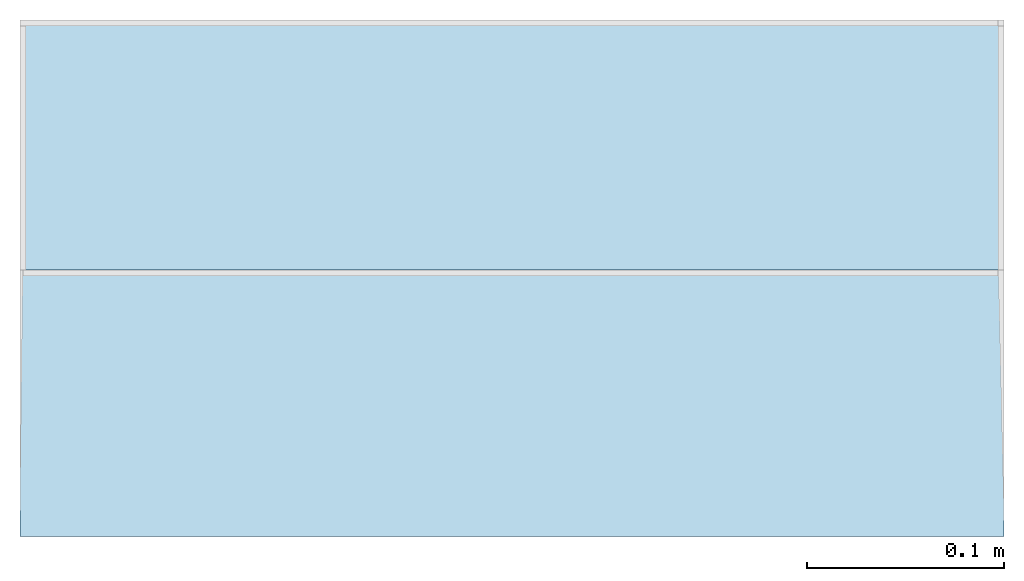
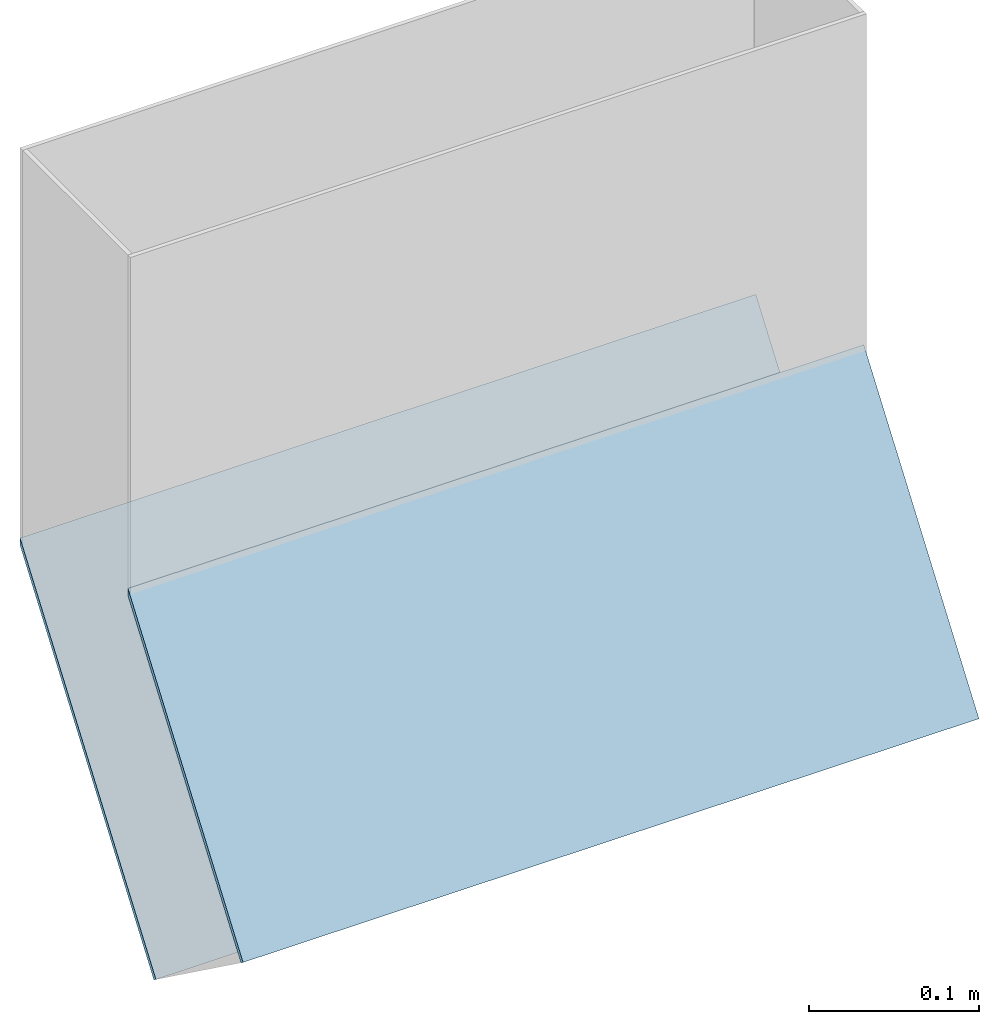
# One storey, part 1 of 2: 2 roofs.
"""IFC2X3 building model written with IfcOpenShell, lengths in metres."""

import ifcopenshell
import ifcopenshell.guid

model = None  # the IFC model being written
_history = None  # IfcOwnerHistory: only IFC2X3 demands one
_inside = {}  # id of a spatial element -> (the spatial element, [elements in it])
_under = {}  # id of a project, library or spatial element -> (it, [spatial elements below it])
_declared = {}  # id of a project -> (the project, [libraries it declares])
_typed = {}  # id of a type object -> (the type object, [elements of that type])
_made_of = {}  # id of a material, layer set ... -> (it, [elements and type objects made of it])


def new_model(schema):
    """Start an empty IFC model of exactly this schema.

    Asked for "IFC4X3", IfcOpenShell would pick the latest addendum, in which some entities
    have other attributes; the version numbers below select the first issue.
    IFC2X3 requires an IfcOwnerHistory on every rooted entity: one is made here for all.
    """
    global model, _history
    if schema == "IFC4X3":
        model = ifcopenshell.file(schema_version=(4, 3, 0, 0))
    else:
        model = ifcopenshell.file(schema=schema)
    _inside.clear()
    _under.clear()
    _declared.clear()
    _typed.clear()
    _made_of.clear()
    _history = None
    if model.schema == "IFC2X3":
        org = make("IfcOrganization", Name="unknown")
        user = make(
            "IfcPersonAndOrganization",
            ThePerson=make("IfcPerson", FamilyName="unknown"),
            TheOrganization=org,
        )
        app = make(
            "IfcApplication",
            ApplicationDeveloper=org,
            Version="unknown",
            ApplicationFullName="unknown",
            ApplicationIdentifier="unknown",
        )
        _history = make(
            "IfcOwnerHistory",
            OwningUser=user,
            OwningApplication=app,
            ChangeAction="ADDED",
            CreationDate=0,
        )
    return model


def make(cls, **values):
    """One entity of the class cls with the attributes given. An attribute that is None is left unset."""
    return model.create_entity(
        cls, **{name: value for name, value in values.items() if value is not None}
    )


def entity(cls, *values):
    """Any entity or typed value of the class cls, its attributes in the order of the schema. None: left unset."""
    e = model.create_entity(cls)
    for i, value in enumerate(values):
        if value is not None:
            e[i] = value
    return e


def rooted(cls, **values):
    """An entity with a GlobalId (a new one), such as an element, a storey or a relation."""
    return make(cls, GlobalId=ifcopenshell.guid.new(), OwnerHistory=_history, **values)


def si_unit(unit_type, name, prefix=None):
    """IfcSIUnit, for example si_unit("LENGTHUNIT", "METRE", prefix="MILLI")."""
    return make("IfcSIUnit", UnitType=unit_type, Prefix=prefix, Name=name)


def converted_unit(unit_type, name, factor, base, dimensions=None, offset=None):
    """IfcConversionBasedUnit, such as the inch: factor (a typed value) times the base unit."""
    return make(
        "IfcConversionBasedUnit"
        if offset is None
        else "IfcConversionBasedUnitWithOffset",
        ConversionOffset=offset,
        Dimensions=None
        if dimensions is None
        else entity("IfcDimensionalExponents", *dimensions),
        UnitType=unit_type,
        Name=name,
        ConversionFactor=make(
            "IfcMeasureWithUnit", ValueComponent=factor, UnitComponent=base
        ),
    )


def derived_unit(unit_type, elements):
    """IfcDerivedUnit: a product of units, each with its exponent."""
    return make(
        "IfcDerivedUnit",
        Elements=[
            make("IfcDerivedUnitElement", Unit=unit, Exponent=power)
            for unit, power in elements
        ],
        UnitType=unit_type,
    )


def money_unit(currency):
    """IfcMonetaryUnit."""
    return make("IfcMonetaryUnit", Currency=currency)


def assignment(units):
    """IfcUnitAssignment: the units of a project."""
    return None if units is None else make("IfcUnitAssignment", Units=units)


def point(xyz):
    """IfcCartesianPoint."""
    return None if xyz is None else make("IfcCartesianPoint", Coordinates=xyz)


def direction(xyz):
    """IfcDirection."""
    return None if xyz is None else make("IfcDirection", DirectionRatios=xyz)


def frame(location, z_axis=None, x_axis=None):
    """IfcAxis2Placement3D, a coordinate frame: its origin and axes. An axis left out is left unset."""
    return make(
        "IfcAxis2Placement3D",
        Location=point(location),
        Axis=direction(z_axis),
        RefDirection=direction(x_axis),
    )


def origin_with_axes():
    """The frame at (0, 0, 0) with the z axis (0, 0, 1) and the x axis (1, 0, 0) written out."""
    return frame((0.0, 0.0, 0.0), z_axis=(0.0, 0.0, 1.0), x_axis=(1.0, 0.0, 0.0))


def place(relative_to, where):
    """IfcLocalPlacement: puts the frame where relative to a parent placement (None: the world)."""
    return make(
        "IfcLocalPlacement", PlacementRelTo=relative_to, RelativePlacement=where
    )


def context(
    kind, dimensions, precision=None, world=None, true_north=None, identifier=None
):
    """IfcGeometricRepresentationContext, for example the 3D "Model" context."""
    return make(
        "IfcGeometricRepresentationContext",
        ContextIdentifier=identifier,
        ContextType=kind,
        CoordinateSpaceDimension=dimensions,
        Precision=precision,
        WorldCoordinateSystem=world,
        TrueNorth=true_north,
    )


def subcontext(parent, identifier, kind, view, scale=None):
    """IfcGeometricRepresentationSubContext, for example "Body" below "Model"."""
    return make(
        "IfcGeometricRepresentationSubContext",
        ContextIdentifier=identifier,
        ContextType=kind,
        ParentContext=parent,
        TargetScale=scale,
        TargetView=view,
    )


def project(units=None, contexts=None):
    """IfcProject with its units and contexts."""
    return rooted(
        "IfcProject",
        Name="project",
        RepresentationContexts=contexts,
        UnitsInContext=assignment(units),
    )


def spatial(cls, under=None, at=None, **own):
    """A site, building, storey or space (cls), placed at a placement, below another one or the project."""
    s = rooted(cls, ObjectPlacement=at, **own)
    if under is not None:
        _under.setdefault(under.id(), (under, []))[1].append(s)
    return s


def faces_of(points, faces, orient=None, outer=None):
    """IfcFace entities. A face is a list of loops; a loop is a list of indices into points, from 0.

    orient and outer hold one flag for each loop. By default every Orientation is true, the
    first loop of a face is its IfcFaceOuterBound and the others are IfcFaceBound.
    """
    made = []
    for i, loops in enumerate(faces):
        bounds = []
        for j, loop in enumerate(loops):
            is_outer = j == 0 if outer is None else outer[i][j]
            bounds.append(
                make(
                    "IfcFaceOuterBound" if is_outer else "IfcFaceBound",
                    Bound=make("IfcPolyLoop", Polygon=[points[k] for k in loop]),
                    Orientation=True if orient is None else orient[i][j],
                )
            )
        made.append(make("IfcFace", Bounds=bounds))
    return made


def faceted_brep(points, faces, orient=None, outer=None, voids=None):
    """IfcFacetedBrep: a solid bounded by flat faces; with voids (closed shells), ...WithVoids."""
    shared = [point(p) for p in points]
    hull = make("IfcClosedShell", CfsFaces=faces_of(shared, faces, orient, outer))
    if voids is None:
        return make("IfcFacetedBrep", Outer=hull)
    return make(
        "IfcFacetedBrepWithVoids",
        Outer=hull,
        Voids=[
            make(cls, CfsFaces=faces_of(shared, fs, o, b)) for cls, fs, o, b in voids
        ],
    )


def shape(context_of_items, identifier, shape_type, items):
    """IfcShapeRepresentation: the items that make up one representation, for example the "Body"."""
    return make(
        "IfcShapeRepresentation",
        ContextOfItems=context_of_items,
        RepresentationIdentifier=identifier,
        RepresentationType=shape_type,
        Items=items,
    )


def material(Name=None, Category=None):
    """IfcMaterial."""
    return make("IfcMaterial", Name=Name, Category=Category)


def made_of(thing, what):
    """Note that an element or type object is made of a material, layer set ...; save() writes the relation."""
    if what is not None:
        _made_of.setdefault(what.id(), (what, []))[1].append(thing)
    return thing


def element(
    cls,
    number,
    at=None,
    inside=None,
    cuts=None,
    type_object=None,
    material=None,
    context=None,
    identifier="Body",
    shape_type=None,
    held_by="IfcProductDefinitionShape",
    body=None,
    shapes=None,
    **own,
):
    """One element of the class cls, such as IfcWall. Its Tag is "e" and its number.

    at: its placement. inside: the storey or other place that contains it. cuts: it is an
    opening in that element (IfcRelVoidsElement). A single representation is given by context,
    identifier, shape_type and body (its items); several are given by shapes. held_by: the class
    of the entity that holds the representations. save() writes the other relations.
    """
    e = rooted(cls, Tag="e%d" % number, ObjectPlacement=at, **own)
    if body is not None:
        shapes = [shape(context, identifier, shape_type, body)]
    if shapes is not None:
        e.Representation = make(held_by, Representations=shapes)
    if inside is not None:
        _inside.setdefault(inside.id(), (inside, []))[1].append(e)
    if cuts is not None:
        rooted(
            "IfcRelVoidsElement", RelatingBuildingElement=cuts, RelatedOpeningElement=e
        )
    if type_object is not None:
        _typed.setdefault(type_object.id(), (type_object, []))[1].append(e)
    return made_of(e, material)


def aggregate(whole, parts):
    """IfcRelAggregates: a whole, such as a stair, and the parts it consists of."""
    return rooted("IfcRelAggregates", RelatingObject=whole, RelatedObjects=parts)


def save(model, path):
    """Write the relations noted so far, then the file.

    IfcRelAggregates (storeys below a building ...), IfcRelContainedInSpatialStructure (elements
    in a storey), IfcRelDefinesByType, IfcRelAssociatesMaterial and IfcRelDeclares: one each for
    every whole, place, type object, material and project.
    """
    for whole, parts in _under.values():
        aggregate(whole, parts)
    for where, things in _inside.values():
        rooted(
            "IfcRelContainedInSpatialStructure",
            RelatedElements=things,
            RelatingStructure=where,
        )
    for kind, things in _typed.values():
        rooted("IfcRelDefinesByType", RelatedObjects=things, RelatingType=kind)
    for what, things in _made_of.values():
        rooted("IfcRelAssociatesMaterial", RelatedObjects=things, RelatingMaterial=what)
    for by, libraries in _declared.values():
        rooted("IfcRelDeclares", RelatingContext=by, RelatedDefinitions=libraries)
    model.write(path)


model = new_model("IFC2X3")

# Units and contexts
model_context = context("Model", 3, precision=1e-05, world=origin_with_axes(), true_north=direction((0.0, 1.0)))
plan_context = context("Plan", 3, precision=1e-05, world=origin_with_axes(), true_north=direction((0.0, 1.0)))
body_context = subcontext(model_context, "Body", "Model", "MODEL_VIEW")
ifc_project = project(units=[si_unit("LENGTHUNIT", "METRE"), si_unit("AREAUNIT", "SQUARE_METRE"), si_unit("VOLUMEUNIT", "CUBIC_METRE"), converted_unit("PLANEANGLEUNIT", "DEGREE", entity("IfcPlaneAngleMeasure", 0.0174532925199), si_unit("PLANEANGLEUNIT", "RADIAN"), dimensions=[0, 0, 0, 0, 0, 0, 0]), si_unit("SOLIDANGLEUNIT", "STERADIAN"), money_unit("CHF"), converted_unit("TIMEUNIT", "Year", entity("IfcTimeMeasure", 31556926.0), si_unit("TIMEUNIT", "SECOND"), dimensions=[0, 0, 1, 0, 0, 0, 0]), si_unit("MASSUNIT", "GRAM", prefix="KILO"), si_unit("THERMODYNAMICTEMPERATUREUNIT", "DEGREE_CELSIUS"), si_unit("LUMINOUSINTENSITYUNIT", "LUMEN"), si_unit("ENERGYUNIT", "JOULE", prefix="MEGA"), derived_unit("THERMALCONDUCTANCEUNIT", [(si_unit("POWERUNIT", "WATT"), 1), (si_unit("LENGTHUNIT", "METRE"), -1), (si_unit("THERMODYNAMICTEMPERATUREUNIT", "KELVIN"), -1)]), derived_unit("SPECIFICHEATCAPACITYUNIT", [(si_unit("ENERGYUNIT", "JOULE"), 1), (si_unit("MASSUNIT", "GRAM", prefix="KILO"), -1), (si_unit("THERMODYNAMICTEMPERATUREUNIT", "KELVIN"), -1)]), derived_unit("MASSDENSITYUNIT", [(si_unit("MASSUNIT", "GRAM", prefix="KILO"), 1), (si_unit("VOLUMEUNIT", "CUBIC_METRE"), -1)])], contexts=[model_context, plan_context])

# Site, building, storey
site_placement = place(None, origin_with_axes())
site = spatial("IfcSite", under=ifc_project, at=site_placement, CompositionType="ELEMENT")
building_placement = place(site_placement, origin_with_axes())
building = spatial("IfcBuilding", under=site, at=building_placement, CompositionType="ELEMENT")
storey_placement = place(building_placement, frame((0.0, 0.0, -2.96), z_axis=(0.0, 0.0, 1.0), x_axis=(1.0, 0.0, 0.0)))
storey = spatial("IfcBuildingStorey", under=building, at=storey_placement, Name="UG01", CompositionType="ELEMENT", Elevation=-2.96)

# Roofs
ifc_material = material(Name="Allgemein, Aussen")
roof_1_placement = place(storey_placement, frame((1.76729741952e-10, -2.2894930396e-10, 2.96), z_axis=(0.0, 0.0, 1.0), x_axis=(1.0, 0.0, 0.0)))
element("IfcRoof", 1, at=roof_1_placement, inside=storey, material=ifc_material, Name="Dach-003", ShapeType="NOTDEFINED", context=body_context, shape_type="Brep", body=[
    faceted_brep([(9.1152243682, -8.09743070609, -0.28027621526), (9.1152243682, -8.25737500117, -0.500420651298), (9.61522436814, -8.25737500117, -0.500420651298), (9.61522436814, -8.09743070609, -0.28027621526), (9.115224368, -8.25496715349, -0.502242632474), (9.115224368, -8.09743070583, -0.285412314535), (9.61522436857, -8.25496715349, -0.502242632474), (9.61522436857, -8.09743070583, -0.285412314535)], [[[0, 1, 2, 3]], [[4, 1, 0, 5]], [[1, 4, 2]], [[2, 6, 7, 3]], [[5, 0, 3, 7]], [[4, 5, 7, 6]], [[2, 4, 6]]]),
])
roof_2_placement = place(storey_placement, frame((1.76729741952e-10, -2.2894930396e-10, 2.96), z_axis=(0.0, 0.0, 1.0), x_axis=(1.0, 0.0, 0.0)))
element("IfcRoof", 2, at=roof_2_placement, inside=storey, material=ifc_material, Name="Dach-003", ShapeType="NOTDEFINED", context=body_context, shape_type="Brep", body=[
    faceted_brep([(9.1152243682, -8.3599272765, -0.425984639359), (9.61522436814, -8.3599272765, -0.425984639359), (9.61522436814, -8.22443070609, -0.23948960955), (9.1152243682, -8.22443070609, -0.23948960955), (9.115224368, -8.357484916, -0.427759118136), (9.61522436857, -8.357484916, -0.427759118136), (9.61522436857, -8.22443070583, -0.244625708824), (9.115224368, -8.22443070583, -0.244625708824)], [[[0, 1, 2, 3]], [[0, 4, 1]], [[1, 5, 6, 2]], [[7, 3, 2, 6]], [[4, 0, 3, 7]], [[1, 4, 5]], [[4, 7, 6, 5]]]),
])

save(model, "model.ifc")
